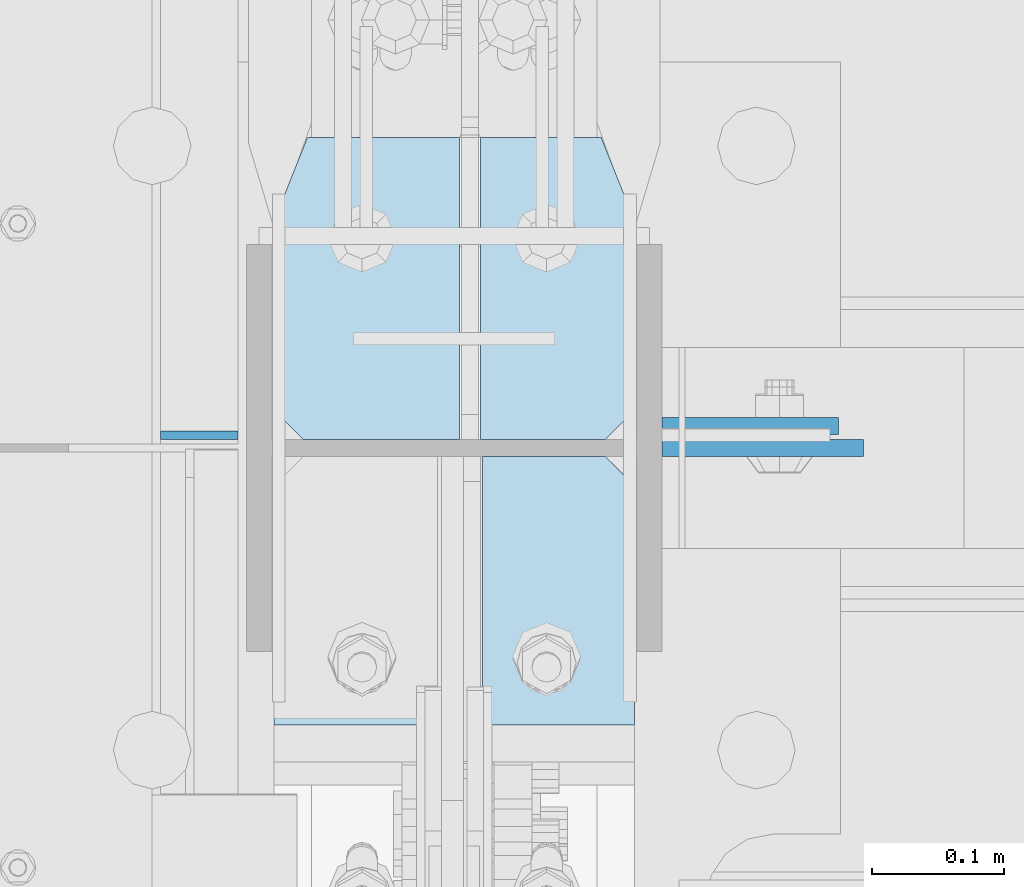
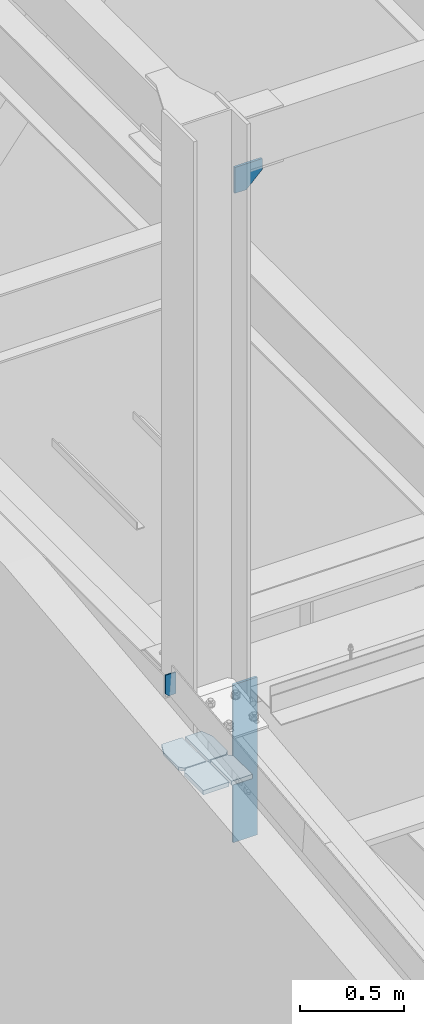
# One storey, part 1057 of 1179: 7 plates, 4 elements without a shape of their own.
"""IFC2X3 building model written with IfcOpenShell, lengths in millimetres."""

from ifc_helpers import new_model, si_unit, frame, origin_with_axes, place, context, subcontext, project, spatial, faceted_brep, material, type_object, element, aggregate, save


model = new_model("IFC2X3")

# Units and contexts
model_context = context("Model", 3, precision=1e-05, world=origin_with_axes())
body_context = subcontext(model_context, "Body", "Model", "MODEL_VIEW")
ifc_project = project(units=[si_unit("LENGTHUNIT", "METRE", prefix="MILLI"), si_unit("AREAUNIT", "SQUARE_METRE"), si_unit("VOLUMEUNIT", "CUBIC_METRE"), si_unit("MASSUNIT", "GRAM", prefix="KILO"), si_unit("TIMEUNIT", "SECOND"), si_unit("PLANEANGLEUNIT", "RADIAN"), si_unit("SOLIDANGLEUNIT", "STERADIAN"), si_unit("THERMODYNAMICTEMPERATUREUNIT", "DEGREE_CELSIUS"), si_unit("LUMINOUSINTENSITYUNIT", "LUMEN")], contexts=[model_context])

# Site, building, storey
site_placement = place(None, origin_with_axes())
site = spatial("IfcSite", under=ifc_project, at=site_placement, CompositionType="ELEMENT")
building_placement = place(site_placement, origin_with_axes())
building = spatial("IfcBuilding", under=site, at=building_placement, Name="Undefined", CompositionType="ELEMENT")
storey_placement = place(building_placement, origin_with_axes())
storey = spatial("IfcBuildingStorey", under=building, at=storey_placement, Name="Undefined", CompositionType="ELEMENT", Elevation=0.0)

# Assembly, plate
assembly_1_placement = place(storey_placement, origin_with_axes())
assembly_1 = element("IfcElementAssembly", 1, at=assembly_1_placement, inside=storey, Name="BEAM", AssemblyPlace="NOTDEFINED", PredefinedType="RIGID_FRAME")
ifc_material_1 = material(Name="STEEL/A36")
plate_type_1 = type_object("IfcPlateType", PredefinedType="NOTDEFINED")
plate_1_placement = place(assembly_1_placement, frame((268.286887452654, 34401.1598191647, 13125.45), z_axis=(-1.0, 0.0, 0.0), x_axis=(0.0, 0.0, 1.0)))
plate_1 = element("IfcPlate", 2, at=plate_1_placement, type_object=plate_type_1, material=ifc_material_1, Name="PLATE", context=body_context, shape_type="Brep", body=[
    faceted_brep([(0.0, -3.17500000000109, 0.0), (2.10385787795531e-05, -3.17500000000291, 39.6868858597326), (2.10385787795531e-05, 3.17500000000291, 39.6868858597326), (0.0, 3.17500000000109, 7.27595761418343e-12), (19.0500303743138, -3.17500000000291, 58.7368850967905), (19.0500303743138, 3.17500000000291, 58.7368850967905), (127.000031137255, -3.17500000000291, 58.7368850967905), (127.000031137255, 3.17500000000291, 58.7368850967905), (127.000000000002, -3.17500000000291, 0.0), (127.000000000002, 3.17500000000291, 0.0)], [[[0, 1, 2, 3]], [[1, 4, 5, 2]], [[4, 6, 7, 5]], [[6, 8, 9, 7]], [[8, 0, 3, 9]], [[5, 7, 9, 3, 2]], [[8, 6, 4, 1, 0]]]),
])
aggregate(assembly_1, [plate_1])

assembly_2_placement = place(storey_placement, origin_with_axes())
assembly_2 = element("IfcElementAssembly", 3, at=assembly_2_placement, inside=storey, Name="PLATE", AssemblyPlace="NOTDEFINED", PredefinedType="RIGID_FRAME")
ifc_material_2 = material(Name="STEEL/A572-GR.50")
plate_type_2 = type_object("IfcPlateType", PredefinedType="NOTDEFINED")
plate_2_placement = place(assembly_2_placement, frame((295.274999995093, 34182.0499938271, 12665.0750000003), z_axis=(0.0, 1.0, 0.0), x_axis=(1.0, 0.0, 0.0)))
plate_2 = element("IfcPlate", 4, at=plate_2_placement, type_object=plate_type_2, material=ifc_material_2, Name="PLATE", context=body_context, shape_type="Brep", body=[
    faceted_brep([(0.0, -12.7, 0.0), (7.94375330315233e-06, -12.7000000000007, 180.975005798595), (7.94375330315233e-06, 12.7000000000007, 180.975005798595), (0.0, 12.7, 0.0), (22.2250093007717, -12.7000000000007, 203.200005206731), (22.2250093007717, 12.7000000000007, 203.200005206731), (142.08125891518, -12.7000000000007, 203.199999957651), (142.08125891518, 12.7000000000007, 203.199999957651), (142.081249995399, -12.7000000000007, -3.20142135024071e-10), (142.081249995399, 12.7000000000007, -3.20142135024071e-10)], [[[0, 1, 2, 3]], [[1, 4, 5, 2]], [[4, 6, 7, 5]], [[6, 8, 9, 7]], [[8, 0, 3, 9]], [[5, 7, 9, 3, 2]], [[8, 6, 4, 1, 0]]]),
])
aggregate(assembly_2, [plate_2])

assembly_3_placement = place(storey_placement, origin_with_axes())
assembly_3 = element("IfcElementAssembly", 5, at=assembly_3_placement, inside=storey, Name="PLATE", AssemblyPlace="NOTDEFINED", PredefinedType="RIGID_FRAME")
plate_type_3 = type_object("IfcPlateType", PredefinedType="NOTDEFINED")
plate_3_placement = place(assembly_3_placement, frame((568.324999995093, 34182.0499938271, 12665.0750000003), z_axis=(0.0, 1.0, 0.0), x_axis=(-1.0, 0.0, 0.0)))
plate_3 = element("IfcPlate", 6, at=plate_3_placement, type_object=plate_type_3, material=ifc_material_2, Name="PLATE", context=body_context, shape_type="Brep", body=[
    faceted_brep([(0.0, -12.7, 0.0), (7.94375330315233e-06, -12.7000000000007, 180.975005798595), (7.94375330315233e-06, 12.7000000000007, 180.975005798595), (0.0, 12.7, 0.0), (22.2250093007717, -12.7000000000007, 203.200005206731), (22.2250093007717, 12.7000000000007, 203.200005206731), (115.093760864306, -12.7000000000007, 203.199999958211), (115.093760864306, 12.7000000000007, 203.199999958211), (115.093749877809, -12.7000000000007, 2.40106601268053e-10), (115.093749877809, 12.7000000000007, 2.40106601268053e-10)], [[[0, 1, 2, 3]], [[1, 4, 5, 2]], [[4, 6, 7, 5]], [[6, 8, 9, 7]], [[8, 0, 3, 9]], [[5, 7, 9, 3, 2]], [[8, 6, 4, 1, 0]]]),
])
aggregate(assembly_3, [plate_3])

# Assembly, plates
assembly_4_placement = place(storey_placement, origin_with_axes())
assembly_4 = element("IfcElementAssembly", 7, at=assembly_4_placement, inside=storey, Name="COLUMN", AssemblyPlace="NOTDEFINED", PredefinedType="RIGID_FRAME")
plate_type_4 = type_object("IfcPlateType", PredefinedType="NOTDEFINED")
plate_4_placement = place(assembly_4_placement, frame((295.275, 34626.55, 12661.9), z_axis=(0.0, -1.0, 0.0), x_axis=(1.0, 0.0, 0.0)))
plate_4 = element("IfcPlate", 8, at=plate_4_placement, type_object=plate_type_4, material=ifc_material_2, Name="PLATE", context=body_context, shape_type="Brep", body=[
    faceted_brep([(0.0, 9.52500000000146, 63.5), (25.4000000000015, 9.52499999999964, -1.45519152283669e-11), (25.4000000000015, -9.52499999999964, -1.45519152283669e-11), (0.0, -9.52500000000146, 63.5), (9.14854700795331e-06, -9.52499999999964, 206.374999618056), (9.14854700795331e-06, 9.52499999999964, 206.374999618056), (22.2250105152449, -9.52499999999964, 228.599999015183), (22.2250105152449, 9.52499999999964, 228.599999015183), (140.493760187644, -9.52499999999964, 228.599993777112), (140.493760187644, 9.52499999999964, 228.599993777112), (140.493750053391, -9.52499999999964, -3.27418092638254e-10), (140.493750053391, 9.52499999999964, -3.27418092638254e-10)], [[[0, 1, 2, 3]], [[4, 5, 0, 3]], [[4, 6, 7, 5]], [[6, 8, 9, 7]], [[8, 10, 11, 9]], [[11, 10, 2, 1]], [[5, 7, 9, 11, 1, 0]], [[10, 8, 6, 4, 3, 2]]]),
])
plate_type_5 = type_object("IfcPlateType", PredefinedType="NOTDEFINED")
plate_5_placement = place(assembly_4_placement, frame((568.325, 34626.55, 12661.9), z_axis=(0.0, -1.0, 0.0), x_axis=(-1.0, 0.0, 0.0)))
plate_5 = element("IfcPlate", 9, at=plate_5_placement, type_object=plate_type_5, material=ifc_material_2, Name="PLATE", context=body_context, shape_type="Brep", body=[
    faceted_brep([(0.0, 9.52500000000146, 63.5), (25.4000000000015, 9.52499999999964, -1.45519152283669e-11), (25.4000000000015, -9.52499999999964, -1.45519152283669e-11), (0.0, -9.52500000000146, 63.5), (9.14854700795331e-06, -9.52499999999964, 206.374999618056), (9.14854700795331e-06, 9.52499999999964, 206.374999618056), (22.2250105152449, -9.52499999999964, 228.599999015183), (22.2250105152449, 9.52499999999964, 228.599999015183), (116.681262094578, -9.52499999999964, 228.599993777199), (116.681262094578, 9.52499999999964, 228.599993777199), (116.681249904955, -9.52499999999964, -2.40106601268053e-10), (116.681249904955, 9.52499999999964, -2.40106601268053e-10)], [[[0, 1, 2, 3]], [[4, 5, 0, 3]], [[4, 6, 7, 5]], [[6, 8, 9, 7]], [[8, 10, 11, 9]], [[11, 10, 2, 1]], [[5, 7, 9, 11, 1, 0]], [[10, 8, 6, 4, 3, 2]]]),
])
plate_type_6 = type_object("IfcPlateType", PredefinedType="NOTDEFINED")
plate_6_placement = place(assembly_4_placement, frame((741.362493896486, 34391.6, 16109.95), z_axis=(-1.0, 0.0, 0.0), x_axis=(0.0, 0.0, -1.0)))
plate_6 = element("IfcPlate", 10, at=plate_6_placement, type_object=plate_type_6, material=ifc_material_1, Name="PLATE", context=body_context, shape_type="Brep", body=[
    faceted_brep([(0.0, -6.34999999999854, 0.0), (0.0, -6.34999999999854, 152.400000000001), (0.0, 6.34999999999854, 152.400000000001), (0.0, 6.34999999999854, 0.0), (152.399993896484, -6.34999999999854, 152.399993896484), (152.399993896484, 6.34999999999854, 152.399993896484), (152.399993896484, -6.34999999999854, 88.6901931762695), (152.399993896484, 6.34999999999854, 88.6901931762695), (63.5, -6.34999999999854, 0.0), (63.5, 6.34999999999854, 0.0)], [[[0, 1, 2, 3]], [[1, 4, 5, 2]], [[4, 6, 7, 5]], [[6, 8, 9, 7]], [[8, 0, 3, 9]], [[5, 7, 9, 3, 2]], [[8, 6, 4, 1, 0]]]),
])
plate_type_7 = type_object("IfcPlateType", PredefinedType="NOTDEFINED")
plate_7_placement = place(assembly_4_placement, frame((588.962499999998, 34408.26875, 13061.95), z_axis=(1.0, 0.0, 0.0), x_axis=(0.0, 0.0, -1.0)))
plate_7 = element("IfcPlate", 11, at=plate_7_placement, type_object=plate_type_7, material=ifc_material_1, Name="PLATE", context=body_context, shape_type="Brep", body=[
    faceted_brep([(0.0, -6.34999999999854, 0.0), (0.0, -6.34999999999854, 133.350000000002), (0.0, 6.34999999999854, 133.350000000002), (0.0, 6.34999999999854, 0.0), (927.1, -6.34999999999854, 133.350000000002), (927.1, 6.34999999999854, 133.350000000002), (927.1, -6.34999999999854, 0.0), (927.1, 6.34999999999854, 0.0)], [[[0, 1, 2, 3]], [[1, 4, 5, 2]], [[4, 6, 7, 5]], [[6, 0, 3, 7]], [[5, 7, 3, 2]], [[6, 4, 1, 0]]]),
])
aggregate(assembly_4, [plate_4, plate_5, plate_6, plate_7])

save(model, "model.ifc")
